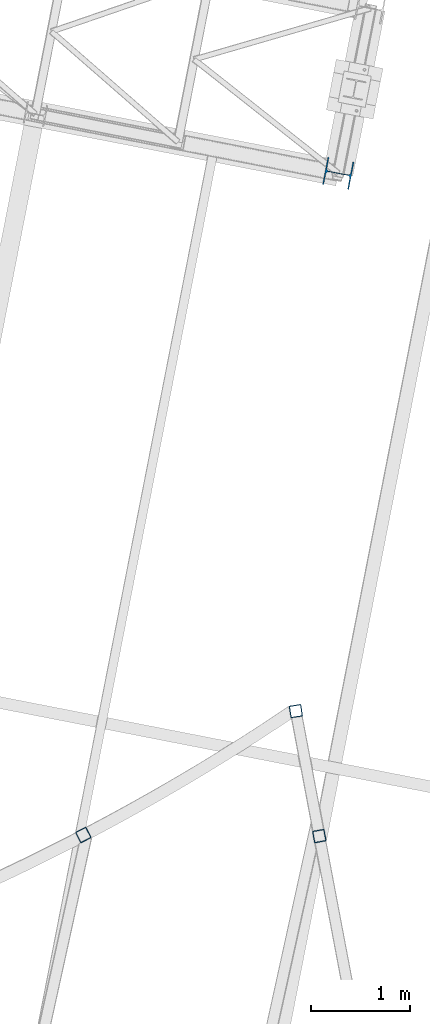
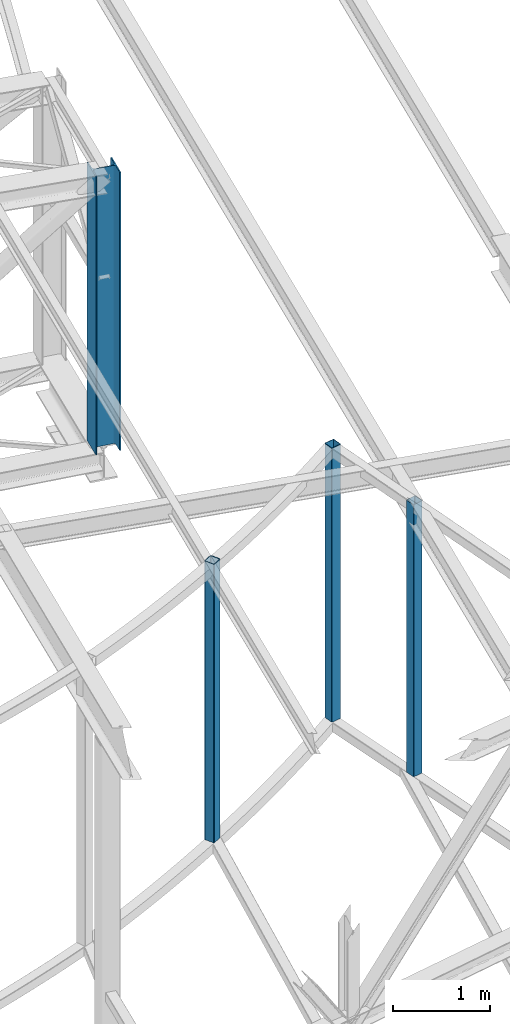
# One storey, part 3 of 215: 4 columns, 4 elements without a shape of their own.
"""IFC2X3 building model written with IfcOpenShell, lengths in millimetres."""

from ifc_helpers import new_model, si_unit, frame, origin_with_axes, origin_2d_with_axis, place, context, subcontext, project, spatial, hollow_rectangle, i_section, extrude, material, type_object, element, aggregate, save


model = new_model("IFC2X3")

# Units and contexts
model_context = context("Model", 3, precision=1e-05, world=origin_with_axes())
body_context = subcontext(model_context, "Body", "Model", "MODEL_VIEW")
ifc_project = project(units=[si_unit("LENGTHUNIT", "METRE", prefix="MILLI"), si_unit("AREAUNIT", "SQUARE_METRE"), si_unit("VOLUMEUNIT", "CUBIC_METRE"), si_unit("MASSUNIT", "GRAM", prefix="KILO"), si_unit("TIMEUNIT", "SECOND"), si_unit("PLANEANGLEUNIT", "RADIAN"), si_unit("SOLIDANGLEUNIT", "STERADIAN"), si_unit("THERMODYNAMICTEMPERATUREUNIT", "DEGREE_CELSIUS"), si_unit("LUMINOUSINTENSITYUNIT", "LUMEN")], contexts=[model_context])

# Site, building, storey
site_placement = place(None, origin_with_axes())
site = spatial("IfcSite", under=ifc_project, at=site_placement, CompositionType="ELEMENT")
building_placement = place(site_placement, origin_with_axes())
building = spatial("IfcBuilding", under=site, at=building_placement, Name="Undefined", CompositionType="ELEMENT")
storey_placement = place(building_placement, origin_with_axes())
storey = spatial("IfcBuildingStorey", under=building, at=storey_placement, Name="Undefined", CompositionType="ELEMENT", Elevation=0.0)

# Assembly, column
assembly_1_placement = place(storey_placement, origin_with_axes())
assembly_1 = element("IfcElementAssembly", 1, at=assembly_1_placement, inside=storey, Name="Steel Assembly", AssemblyPlace="NOTDEFINED", PredefinedType="RIGID_FRAME")
ifc_material = material(Name="STEEL/S275JR")
column_type_1 = type_object("IfcColumnType", PredefinedType="NOTDEFINED")
column_1_placement = place(assembly_1_placement, frame((89121.1836427898, 7629.05626927832, 12198.2551853413), z_axis=(0.0, 0.0, -1.0), x_axis=(0.988349501373161, 0.152201390057465, -8.00000089231709e-09)))
column_1 = element("IfcColumn", 2, at=column_1_placement, type_object=column_type_1, material=ifc_material, Name="LISSE", context=body_context, shape_type="SweptSolid", body=[
    extrude(hollow_rectangle(XDim=120.0, YDim=120.0, WallThickness=5.0, InnerFilletRadius=5.0, OuterFilletRadius=10.0, at=origin_2d_with_axis()), frame((0.0, 0.0, 3432.25439591231), z_axis=(0.0, 0.0, -1.0), x_axis=(0.0, 1.0, 0.0)), (0.0, 0.0, 1.0), 3432.3),
])
aggregate(assembly_1, [column_1])

assembly_2_placement = place(storey_placement, origin_with_axes())
assembly_2 = element("IfcElementAssembly", 3, at=assembly_2_placement, inside=storey, Name="Steel Assembly", AssemblyPlace="NOTDEFINED", PredefinedType="RIGID_FRAME")
column_2_placement = place(assembly_2_placement, frame((89358.1924000971, 6365.63328521757, 12173.1879536438), z_axis=(0.0, 0.0, -1.0), x_axis=(0.185411229953005, -0.98266101775094, 6.00000021070441e-09)))
column_2 = element("IfcColumn", 4, at=column_2_placement, type_object=column_type_1, material=ifc_material, Name="LISSE", context=body_context, shape_type="SweptSolid", body=[
    extrude(hollow_rectangle(XDim=120.0, YDim=120.0, WallThickness=5.0, InnerFilletRadius=5.0, OuterFilletRadius=10.0, at=origin_2d_with_axis()), frame((1.8189894007275e-12, 1.45519152396403e-11, 3407.18716531198), z_axis=(0.0, 0.0, -1.0), x_axis=(0.0, 1.0, 0.0)), (0.0, 0.0, 1.0), 3407.2),
])
aggregate(assembly_2, [column_2])

assembly_3_placement = place(storey_placement, origin_with_axes())
assembly_3 = element("IfcElementAssembly", 5, at=assembly_3_placement, inside=storey, Name="Steel Assembly", AssemblyPlace="NOTDEFINED", PredefinedType="RIGID_FRAME")
column_3_placement = place(assembly_3_placement, frame((86972.6287166315, 6376.95789592663, 12255.9475130842), z_axis=(0.0, 0.0, -1.0), x_axis=(0.455221212236519, -0.890378373462605, -1.00000033905532e-09)))
column_3 = element("IfcColumn", 6, at=column_3_placement, type_object=column_type_1, material=ifc_material, Name="LISSE", context=body_context, shape_type="SweptSolid", body=[
    extrude(hollow_rectangle(XDim=120.0, YDim=120.0, WallThickness=5.0, InnerFilletRadius=5.0, OuterFilletRadius=10.0, at=origin_2d_with_axis()), frame((-7.27595762103961e-12, 0.0, 3489.9467216719), z_axis=(0.0, 0.0, -1.0), x_axis=(0.0, 1.0, 0.0)), (0.0, 0.0, 1.0), 3489.9),
])
aggregate(assembly_3, [column_3])

assembly_4_placement = place(storey_placement, origin_with_axes())
assembly_4 = element("IfcElementAssembly", 7, at=assembly_4_placement, inside=storey, Name="Steel Assembly", AssemblyPlace="NOTDEFINED", PredefinedType="RIGID_FRAME")
column_type_2 = type_object("IfcColumnType", Name="HEA280", PredefinedType="NOTDEFINED")
column_4_placement = place(assembly_4_placement, frame((89549.9300236097, 13065.4053852236, 12215.1876027399), z_axis=(0.0, 0.0, -1.0), x_axis=(-0.981546631935819, 0.191222930987497, 2.00000067694074e-09)))
column_4 = element("IfcColumn", 8, at=column_4_placement, type_object=column_type_2, material=ifc_material, Name="MONTANT", ObjectType="HEA280", context=body_context, shape_type="SweptSolid", body=[
    extrude(i_section(OverallWidth=280.0, OverallDepth=270.0, WebThickness=8.0, FlangeThickness=13.0, FilletRadius=24.0, at=origin_2d_with_axis()), frame((1.45519152276461e-11, -3.63797880673135e-12, 3485.18760271087), z_axis=(0.0, 0.0, -1.0), x_axis=(0.0, 1.0, 0.0)), (0.0, 0.0, 1.0), 3485.2),
])
aggregate(assembly_4, [column_4])

save(model, "model.ifc")
